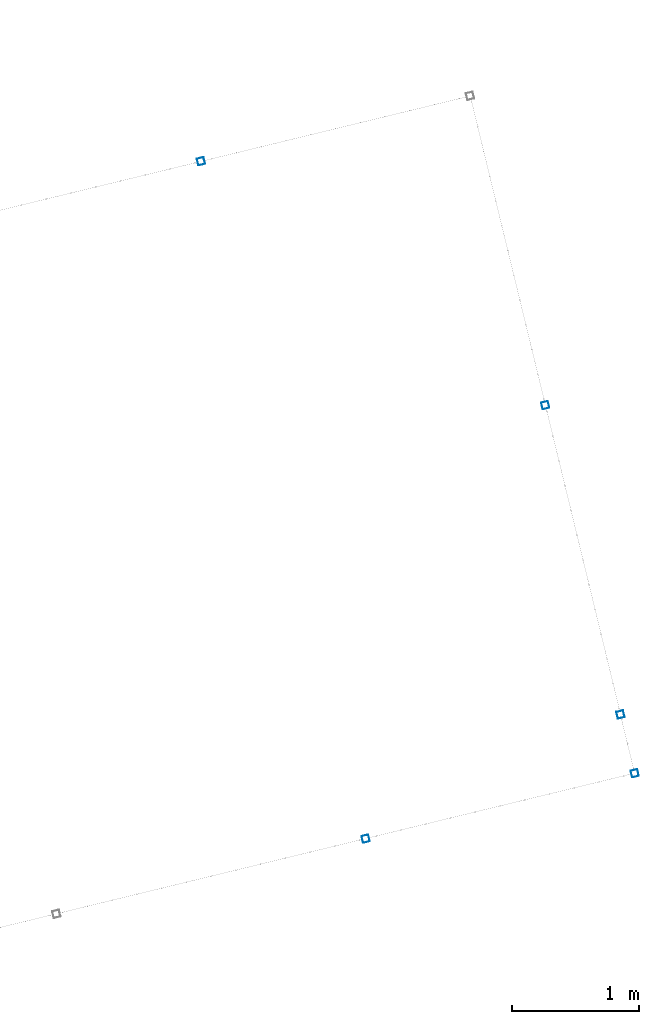
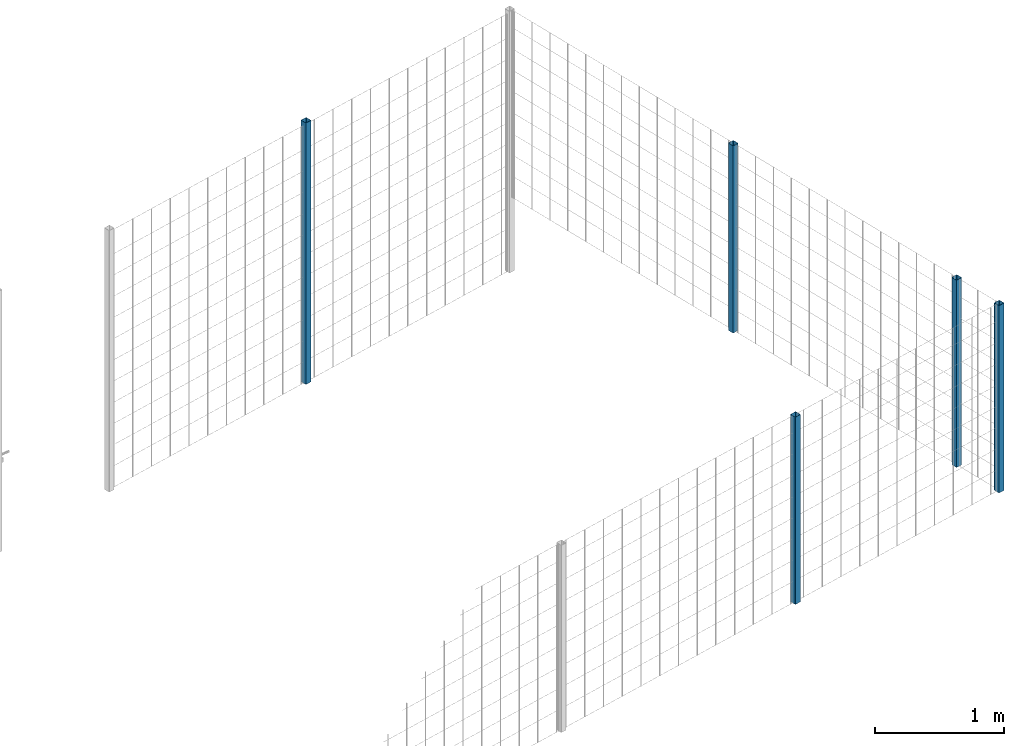
# One storey, part 4 of 10: 5 beams.
"""IFC2X3 building model written with IfcOpenShell, lengths in millimetres."""

from ifc_helpers import new_model, entity, si_unit, converted_unit, derived_unit, direction, frame, frame_2d, origin, place, context, subcontext, project, spatial, polyline, circle_curve, parameter, trimmed, segment, composite_curve, outline, extrude, material, type_object, element, save


model = new_model("IFC2X3")

# Units and contexts
model_context = context("Model", 3, precision=0.01, world=origin(), true_north=direction((6.12303176911189e-17, 1.0)))
body_context = subcontext(model_context, "Body", "Model", "MODEL_VIEW")
ifc_project = project(units=[si_unit("LENGTHUNIT", "METRE", prefix="MILLI"), si_unit("AREAUNIT", "SQUARE_METRE"), si_unit("VOLUMEUNIT", "CUBIC_METRE"), converted_unit("PLANEANGLEUNIT", "DEGREE", entity("IfcRatioMeasure", 0.0174532925199433), si_unit("PLANEANGLEUNIT", "RADIAN"), dimensions=[0, 0, 0, 0, 0, 0, 0]), si_unit("MASSUNIT", "GRAM", prefix="KILO"), derived_unit("MASSDENSITYUNIT", [(si_unit("MASSUNIT", "GRAM", prefix="KILO"), 1), (si_unit("LENGTHUNIT", "METRE"), -3)]), derived_unit("MOMENTOFINERTIAUNIT", [(si_unit("LENGTHUNIT", "METRE"), 4)]), si_unit("TIMEUNIT", "SECOND"), si_unit("FREQUENCYUNIT", "HERTZ"), si_unit("THERMODYNAMICTEMPERATUREUNIT", "DEGREE_CELSIUS"), derived_unit("THERMALTRANSMITTANCEUNIT", [(si_unit("MASSUNIT", "GRAM", prefix="KILO"), 1), (si_unit("THERMODYNAMICTEMPERATUREUNIT", "KELVIN"), -1), (si_unit("TIMEUNIT", "SECOND"), -3)]), derived_unit("VOLUMETRICFLOWRATEUNIT", [(si_unit("LENGTHUNIT", "METRE"), 3), (si_unit("TIMEUNIT", "SECOND"), -1)]), derived_unit("MASSFLOWRATEUNIT", [(si_unit("MASSUNIT", "GRAM", prefix="KILO"), 1), (si_unit("TIMEUNIT", "SECOND"), -1)]), derived_unit("ROTATIONALFREQUENCYUNIT", [(si_unit("TIMEUNIT", "SECOND"), -1)]), si_unit("ELECTRICCURRENTUNIT", "AMPERE"), si_unit("ELECTRICVOLTAGEUNIT", "VOLT"), si_unit("POWERUNIT", "WATT"), si_unit("FORCEUNIT", "NEWTON", prefix="KILO"), si_unit("ILLUMINANCEUNIT", "LUX"), si_unit("LUMINOUSFLUXUNIT", "LUMEN"), si_unit("LUMINOUSINTENSITYUNIT", "CANDELA"), derived_unit("USERDEFINED", [(si_unit("MASSUNIT", "GRAM", prefix="KILO"), -1), (si_unit("LENGTHUNIT", "METRE"), -2), (si_unit("TIMEUNIT", "SECOND"), 3), (si_unit("LUMINOUSFLUXUNIT", "LUMEN"), 1)]), derived_unit("LINEARVELOCITYUNIT", [(si_unit("LENGTHUNIT", "METRE"), 1), (si_unit("TIMEUNIT", "SECOND"), -1)]), si_unit("PRESSUREUNIT", "PASCAL"), derived_unit("USERDEFINED", [(si_unit("LENGTHUNIT", "METRE"), -2), (si_unit("MASSUNIT", "GRAM", prefix="KILO"), 1), (si_unit("TIMEUNIT", "SECOND"), -2)]), derived_unit("LINEARFORCEUNIT", [(si_unit("MASSUNIT", "GRAM", prefix="KILO"), 1), (si_unit("LENGTHUNIT", "METRE"), 1), (si_unit("TIMEUNIT", "SECOND"), -2), (si_unit("LENGTHUNIT", "METRE"), -1)]), derived_unit("PLANARFORCEUNIT", [(si_unit("MASSUNIT", "GRAM", prefix="KILO"), 1), (si_unit("LENGTHUNIT", "METRE"), 1), (si_unit("TIMEUNIT", "SECOND"), -2), (si_unit("LENGTHUNIT", "METRE"), -2)])], contexts=[model_context])

# Site, building, storey
site_placement = place(None, frame((19171.75, -72498.58, 0.0), z_axis=(0.0, 0.0, 1.0), x_axis=(0.971695960795463, 0.236234967296933, 0.0)))
site = spatial("IfcSite", under=ifc_project, at=site_placement, CompositionType="ELEMENT")
building_placement = place(site_placement, origin())
building = spatial("IfcBuilding", under=site, at=building_placement, CompositionType="ELEMENT")
storey_placement = place(building_placement, origin())
storey = spatial("IfcBuildingStorey", under=building, at=storey_placement, Name="01", CompositionType="ELEMENT", Elevation=0.0)

# Beams
ifc_material = material(Name="345")
beam_type = type_object("IfcBeamType", PredefinedType="NOTDEFINED")
beam_1_placement = place(storey_placement, frame((7670.9, 5570.9, 0.0), z_axis=(1.0, 0.0, 0.0), x_axis=(0.0, 0.0, -1.0)))
element("IfcBeam", 1, at=beam_1_placement, inside=storey, type_object=beam_type, material=ifc_material, context=body_context, shape_type="SweptSolid", body=[
    extrude(outline(composite_curve([segment(trimmed(circle_curve(frame_2d((24.7, -24.7), x_axis=(1.0, 0.0)), 2.79999999999974), [parameter(269.999999999999)], [parameter(1.32311074748882e-12)], True, "PARAMETER"), True, "CONTINUOUS"), segment(polyline([(27.5, -24.7), (27.5, 24.7)]), True, "CONTINUOUS"), segment(trimmed(circle_curve(frame_2d((24.7, 24.7), x_axis=(1.0, 0.0)), 2.79999999999845), [parameter(1.32311074748882e-12)], [parameter(90.0000000000001)], True, "PARAMETER"), True, "CONTINUOUS"), segment(polyline([(24.7, 27.5), (-24.7, 27.5)]), True, "CONTINUOUS"), segment(trimmed(circle_curve(frame_2d((-24.7, 24.7), x_axis=(1.0, 0.0)), 2.79999999999845), [parameter(90.0000000000001)], [parameter(180.0)], True, "PARAMETER"), True, "CONTINUOUS"), segment(polyline([(-27.5, 24.7), (-27.5, -24.7)]), True, "CONTINUOUS"), segment(trimmed(circle_curve(frame_2d((-24.7, -24.7), x_axis=(1.0, 0.0)), 2.79999999999845), [parameter(180.0)], [parameter(269.999999999998)], True, "PARAMETER"), True, "CONTINUOUS"), segment(polyline([(-24.7, -27.5), (24.7, -27.5)]), True, "CONTINUOUS")], self_intersect=False), holes=[composite_curve([segment(polyline([(23.3, -26.1), (-23.3, -26.1)]), True, "CONTINUOUS"), segment(trimmed(circle_curve(frame_2d((-23.3, -23.3), x_axis=(1.0, 0.0)), 2.79999999999973), [parameter(180.0)], [parameter(270.0)], True, "PARAMETER"), False, "CONTINUOUS"), segment(polyline([(-26.1, -23.3), (-26.1, 23.3)]), True, "CONTINUOUS"), segment(trimmed(circle_curve(frame_2d((-23.3, 23.3), x_axis=(1.0, 0.0)), 2.79999999999973), [parameter(90.0000000000004)], [parameter(180.0)], True, "PARAMETER"), False, "CONTINUOUS"), segment(polyline([(-23.3, 26.1), (23.3, 26.1)]), True, "CONTINUOUS"), segment(trimmed(circle_curve(frame_2d((23.3, 23.3), x_axis=(1.0, 0.0)), 2.79999999999973), [parameter(3.56222124323914e-13)], [parameter(90.0000000000004)], True, "PARAMETER"), False, "CONTINUOUS"), segment(polyline([(26.1, 23.3), (26.1, -23.3)]), True, "CONTINUOUS"), segment(trimmed(circle_curve(frame_2d((23.3, -23.3), x_axis=(1.0, 0.0)), 2.80000000000034), [parameter(270.0)], [parameter(4.57999874130747e-13)], True, "PARAMETER"), False, "CONTINUOUS")], self_intersect=False)]), frame((-2465.98, 29.1, 29.1), z_axis=(1.0, 0.0, 0.0), x_axis=(0.0, 1.0, 0.0)), (0.0, 0.0, 1.0), 2465.97922445826),
])
beam_2_placement = place(storey_placement, frame((9845.9, 3070.9, 700.0), z_axis=(1.0, 0.0, 0.0), x_axis=(0.0, 0.0, 1.0)))
element("IfcBeam", 2, at=beam_2_placement, inside=storey, type_object=beam_type, material=ifc_material, context=body_context, shape_type="SweptSolid", body=[
    extrude(outline(composite_curve([segment(trimmed(circle_curve(frame_2d((24.7, -24.7), x_axis=(1.0, 0.0)), 2.79999999999974), [parameter(269.999999999999)], [parameter(1.32311074748882e-12)], True, "PARAMETER"), True, "CONTINUOUS"), segment(polyline([(27.5, -24.7), (27.5, 24.7)]), True, "CONTINUOUS"), segment(trimmed(circle_curve(frame_2d((24.7, 24.7), x_axis=(1.0, 0.0)), 2.79999999999845), [parameter(1.32311074748882e-12)], [parameter(90.0000000000001)], True, "PARAMETER"), True, "CONTINUOUS"), segment(polyline([(24.7, 27.5), (-24.7, 27.5)]), True, "CONTINUOUS"), segment(trimmed(circle_curve(frame_2d((-24.7, 24.7), x_axis=(1.0, 0.0)), 2.79999999999845), [parameter(90.0000000000001)], [parameter(180.0)], True, "PARAMETER"), True, "CONTINUOUS"), segment(polyline([(-27.5, 24.7), (-27.5, -24.7)]), True, "CONTINUOUS"), segment(trimmed(circle_curve(frame_2d((-24.7, -24.7), x_axis=(1.0, 0.0)), 2.79999999999845), [parameter(180.0)], [parameter(269.999999999998)], True, "PARAMETER"), True, "CONTINUOUS"), segment(polyline([(-24.7, -27.5), (24.7, -27.5)]), True, "CONTINUOUS")], self_intersect=False), holes=[composite_curve([segment(polyline([(23.3, -26.1), (-23.3, -26.1)]), True, "CONTINUOUS"), segment(trimmed(circle_curve(frame_2d((-23.3, -23.3), x_axis=(1.0, 0.0)), 2.79999999999973), [parameter(180.0)], [parameter(270.0)], True, "PARAMETER"), False, "CONTINUOUS"), segment(polyline([(-26.1, -23.3), (-26.1, 23.3)]), True, "CONTINUOUS"), segment(trimmed(circle_curve(frame_2d((-23.3, 23.3), x_axis=(1.0, 0.0)), 2.79999999999973), [parameter(90.0000000000004)], [parameter(180.0)], True, "PARAMETER"), False, "CONTINUOUS"), segment(polyline([(-23.3, 26.1), (23.3, 26.1)]), True, "CONTINUOUS"), segment(trimmed(circle_curve(frame_2d((23.3, 23.3), x_axis=(1.0, 0.0)), 2.79999999999973), [parameter(3.56222124323914e-13)], [parameter(90.0000000000004)], True, "PARAMETER"), False, "CONTINUOUS"), segment(polyline([(26.1, 23.3), (26.1, -23.3)]), True, "CONTINUOUS"), segment(trimmed(circle_curve(frame_2d((23.3, -23.3), x_axis=(1.0, 0.0)), 2.80000000000034), [parameter(270.0)], [parameter(4.57999874130747e-13)], True, "PARAMETER"), False, "CONTINUOUS")], self_intersect=False)]), frame((0.0, -29.1, 29.1), z_axis=(1.0, 0.0, 0.0), x_axis=(0.0, -1.0, 0.0)), (0.0, 0.0, 1.0), 1765.0),
])
beam_3_placement = place(storey_placement, frame((9845.9, 570.9, 699.02), z_axis=(1.0, 0.0, 0.0), x_axis=(0.0, 0.0, 1.0)))
element("IfcBeam", 3, at=beam_3_placement, inside=storey, type_object=beam_type, material=ifc_material, context=body_context, shape_type="SweptSolid", body=[
    extrude(outline(composite_curve([segment(trimmed(circle_curve(frame_2d((24.7, -24.7), x_axis=(1.0, 0.0)), 2.79999999999974), [parameter(269.999999999999)], [parameter(1.32311074748882e-12)], True, "PARAMETER"), True, "CONTINUOUS"), segment(polyline([(27.5, -24.7), (27.5, 24.7)]), True, "CONTINUOUS"), segment(trimmed(circle_curve(frame_2d((24.7, 24.7), x_axis=(1.0, 0.0)), 2.79999999999845), [parameter(1.32311074748882e-12)], [parameter(90.0000000000001)], True, "PARAMETER"), True, "CONTINUOUS"), segment(polyline([(24.7, 27.5), (-24.7, 27.5)]), True, "CONTINUOUS"), segment(trimmed(circle_curve(frame_2d((-24.7, 24.7), x_axis=(1.0, 0.0)), 2.79999999999845), [parameter(90.0000000000001)], [parameter(180.0)], True, "PARAMETER"), True, "CONTINUOUS"), segment(polyline([(-27.5, 24.7), (-27.5, -24.7)]), True, "CONTINUOUS"), segment(trimmed(circle_curve(frame_2d((-24.7, -24.7), x_axis=(1.0, 0.0)), 2.79999999999845), [parameter(180.0)], [parameter(269.999999999998)], True, "PARAMETER"), True, "CONTINUOUS"), segment(polyline([(-24.7, -27.5), (24.7, -27.5)]), True, "CONTINUOUS")], self_intersect=False), holes=[composite_curve([segment(polyline([(23.3, -26.1), (-23.3, -26.1)]), True, "CONTINUOUS"), segment(trimmed(circle_curve(frame_2d((-23.3, -23.3), x_axis=(1.0, 0.0)), 2.79999999999973), [parameter(180.0)], [parameter(270.0)], True, "PARAMETER"), False, "CONTINUOUS"), segment(polyline([(-26.1, -23.3), (-26.1, 23.3)]), True, "CONTINUOUS"), segment(trimmed(circle_curve(frame_2d((-23.3, 23.3), x_axis=(1.0, 0.0)), 2.79999999999973), [parameter(90.0000000000004)], [parameter(180.0)], True, "PARAMETER"), False, "CONTINUOUS"), segment(polyline([(-23.3, 26.1), (23.3, 26.1)]), True, "CONTINUOUS"), segment(trimmed(circle_curve(frame_2d((23.3, 23.3), x_axis=(1.0, 0.0)), 2.79999999999973), [parameter(3.56222124323914e-13)], [parameter(90.0000000000004)], True, "PARAMETER"), False, "CONTINUOUS"), segment(polyline([(26.1, 23.3), (26.1, -23.3)]), True, "CONTINUOUS"), segment(trimmed(circle_curve(frame_2d((23.3, -23.3), x_axis=(1.0, 0.0)), 2.80000000000034), [parameter(270.0)], [parameter(4.57999874130747e-13)], True, "PARAMETER"), False, "CONTINUOUS")], self_intersect=False)]), frame((0.0, -29.1, 29.1), z_axis=(1.0, 0.0, 0.0), x_axis=(0.0, -1.0, 0.0)), (0.0, 0.0, 1.0), 1765.97922445826),
])
beam_4_placement = place(storey_placement, frame((9845.9, 95.9, 699.02), z_axis=(1.0, 0.0, 0.0), x_axis=(0.0, 0.0, 1.0)))
element("IfcBeam", 4, at=beam_4_placement, inside=storey, type_object=beam_type, material=ifc_material, context=body_context, shape_type="SweptSolid", body=[
    extrude(outline(composite_curve([segment(trimmed(circle_curve(frame_2d((24.7, -24.7), x_axis=(1.0, 0.0)), 2.79999999999974), [parameter(269.999999999999)], [parameter(1.32311074748882e-12)], True, "PARAMETER"), True, "CONTINUOUS"), segment(polyline([(27.5, -24.7), (27.5, 24.7)]), True, "CONTINUOUS"), segment(trimmed(circle_curve(frame_2d((24.7, 24.7), x_axis=(1.0, 0.0)), 2.79999999999845), [parameter(1.32311074748882e-12)], [parameter(90.0000000000001)], True, "PARAMETER"), True, "CONTINUOUS"), segment(polyline([(24.7, 27.5), (-24.7, 27.5)]), True, "CONTINUOUS"), segment(trimmed(circle_curve(frame_2d((-24.7, 24.7), x_axis=(1.0, 0.0)), 2.79999999999845), [parameter(90.0000000000001)], [parameter(180.0)], True, "PARAMETER"), True, "CONTINUOUS"), segment(polyline([(-27.5, 24.7), (-27.5, -24.7)]), True, "CONTINUOUS"), segment(trimmed(circle_curve(frame_2d((-24.7, -24.7), x_axis=(1.0, 0.0)), 2.79999999999845), [parameter(180.0)], [parameter(269.999999999998)], True, "PARAMETER"), True, "CONTINUOUS"), segment(polyline([(-24.7, -27.5), (24.7, -27.5)]), True, "CONTINUOUS")], self_intersect=False), holes=[composite_curve([segment(polyline([(23.3, -26.1), (-23.3, -26.1)]), True, "CONTINUOUS"), segment(trimmed(circle_curve(frame_2d((-23.3, -23.3), x_axis=(1.0, 0.0)), 2.79999999999973), [parameter(180.0)], [parameter(270.0)], True, "PARAMETER"), False, "CONTINUOUS"), segment(polyline([(-26.1, -23.3), (-26.1, 23.3)]), True, "CONTINUOUS"), segment(trimmed(circle_curve(frame_2d((-23.3, 23.3), x_axis=(1.0, 0.0)), 2.79999999999973), [parameter(90.0000000000004)], [parameter(180.0)], True, "PARAMETER"), False, "CONTINUOUS"), segment(polyline([(-23.3, 26.1), (23.3, 26.1)]), True, "CONTINUOUS"), segment(trimmed(circle_curve(frame_2d((23.3, 23.3), x_axis=(1.0, 0.0)), 2.79999999999973), [parameter(3.56222124323914e-13)], [parameter(90.0000000000004)], True, "PARAMETER"), False, "CONTINUOUS"), segment(polyline([(26.1, 23.3), (26.1, -23.3)]), True, "CONTINUOUS"), segment(trimmed(circle_curve(frame_2d((23.3, -23.3), x_axis=(1.0, 0.0)), 2.80000000000034), [parameter(270.0)], [parameter(4.57999874130747e-13)], True, "PARAMETER"), False, "CONTINUOUS")], self_intersect=False)]), frame((0.0, -29.1, 29.1), z_axis=(1.0, 0.0, 0.0), x_axis=(0.0, -1.0, 0.0)), (0.0, 0.0, 1.0), 1765.97922445826),
])
beam_5_placement = place(storey_placement, frame((7671.13, 95.9, 699.02), z_axis=(1.0, 0.0, 0.0), x_axis=(0.0, 0.0, 1.0)))
element("IfcBeam", 5, at=beam_5_placement, inside=storey, type_object=beam_type, material=ifc_material, context=body_context, shape_type="SweptSolid", body=[
    extrude(outline(composite_curve([segment(trimmed(circle_curve(frame_2d((24.7, -24.7), x_axis=(1.0, 0.0)), 2.79999999999974), [parameter(269.999999999999)], [parameter(1.32311074748882e-12)], True, "PARAMETER"), True, "CONTINUOUS"), segment(polyline([(27.5, -24.7), (27.5, 24.7)]), True, "CONTINUOUS"), segment(trimmed(circle_curve(frame_2d((24.7, 24.7), x_axis=(1.0, 0.0)), 2.79999999999845), [parameter(1.32311074748882e-12)], [parameter(90.0000000000001)], True, "PARAMETER"), True, "CONTINUOUS"), segment(polyline([(24.7, 27.5), (-24.7, 27.5)]), True, "CONTINUOUS"), segment(trimmed(circle_curve(frame_2d((-24.7, 24.7), x_axis=(1.0, 0.0)), 2.79999999999845), [parameter(90.0000000000001)], [parameter(180.0)], True, "PARAMETER"), True, "CONTINUOUS"), segment(polyline([(-27.5, 24.7), (-27.5, -24.7)]), True, "CONTINUOUS"), segment(trimmed(circle_curve(frame_2d((-24.7, -24.7), x_axis=(1.0, 0.0)), 2.79999999999845), [parameter(180.0)], [parameter(269.999999999998)], True, "PARAMETER"), True, "CONTINUOUS"), segment(polyline([(-24.7, -27.5), (24.7, -27.5)]), True, "CONTINUOUS")], self_intersect=False), holes=[composite_curve([segment(polyline([(23.3, -26.1), (-23.3, -26.1)]), True, "CONTINUOUS"), segment(trimmed(circle_curve(frame_2d((-23.3, -23.3), x_axis=(1.0, 0.0)), 2.79999999999973), [parameter(180.0)], [parameter(270.0)], True, "PARAMETER"), False, "CONTINUOUS"), segment(polyline([(-26.1, -23.3), (-26.1, 23.3)]), True, "CONTINUOUS"), segment(trimmed(circle_curve(frame_2d((-23.3, 23.3), x_axis=(1.0, 0.0)), 2.79999999999973), [parameter(90.0000000000004)], [parameter(180.0)], True, "PARAMETER"), False, "CONTINUOUS"), segment(polyline([(-23.3, 26.1), (23.3, 26.1)]), True, "CONTINUOUS"), segment(trimmed(circle_curve(frame_2d((23.3, 23.3), x_axis=(1.0, 0.0)), 2.79999999999973), [parameter(3.56222124323914e-13)], [parameter(90.0000000000004)], True, "PARAMETER"), False, "CONTINUOUS"), segment(polyline([(26.1, 23.3), (26.1, -23.3)]), True, "CONTINUOUS"), segment(trimmed(circle_curve(frame_2d((23.3, -23.3), x_axis=(1.0, 0.0)), 2.80000000000034), [parameter(270.0)], [parameter(4.57999874130747e-13)], True, "PARAMETER"), False, "CONTINUOUS")], self_intersect=False)]), frame((0.0, -29.1, 29.1), z_axis=(1.0, 0.0, 0.0), x_axis=(0.0, -1.0, 0.0)), (0.0, 0.0, 1.0), 1765.97922445826),
])

save(model, "model.ifc")
